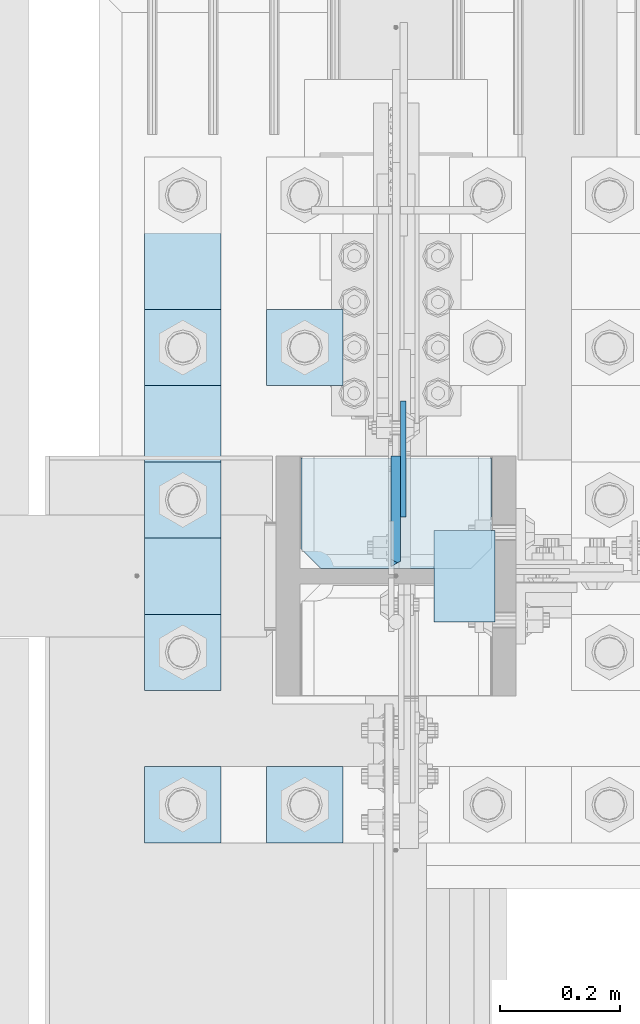
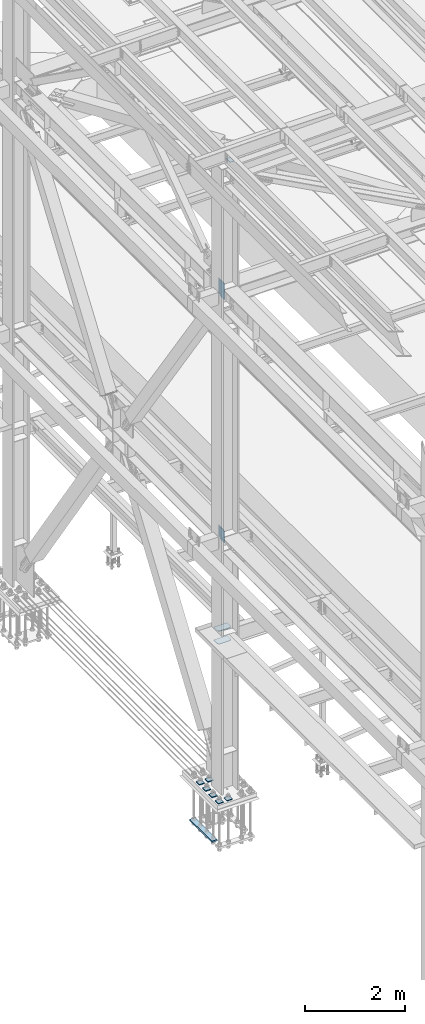
# One storey, part 3339 of 3843: 14 plates, 2 elements without a shape of their own.
"""IFC2X3 building model written with IfcOpenShell, lengths in millimetres."""

from ifc_helpers import new_model, si_unit, frame, origin_with_axes, place, context, subcontext, project, spatial, faceted_brep, material, type_object, element, aggregate, save


model = new_model("IFC2X3")

# Units and contexts
model_context = context("Model", 3, precision=1e-05, world=origin_with_axes())
body_context = subcontext(model_context, "Body", "Model", "MODEL_VIEW")
ifc_project = project(units=[si_unit("LENGTHUNIT", "METRE", prefix="MILLI"), si_unit("AREAUNIT", "SQUARE_METRE"), si_unit("VOLUMEUNIT", "CUBIC_METRE"), si_unit("MASSUNIT", "GRAM", prefix="KILO"), si_unit("TIMEUNIT", "SECOND"), si_unit("PLANEANGLEUNIT", "RADIAN"), si_unit("SOLIDANGLEUNIT", "STERADIAN"), si_unit("THERMODYNAMICTEMPERATUREUNIT", "DEGREE_CELSIUS"), si_unit("LUMINOUSINTENSITYUNIT", "LUMEN")], contexts=[model_context])

# Site, building, storey
site_placement = place(None, origin_with_axes())
site = spatial("IfcSite", under=ifc_project, at=site_placement, CompositionType="ELEMENT")
building_placement = place(site_placement, origin_with_axes())
building = spatial("IfcBuilding", under=site, at=building_placement, Name="Undefined", CompositionType="ELEMENT")
storey_placement = place(building_placement, origin_with_axes())
storey = spatial("IfcBuildingStorey", under=building, at=storey_placement, Name="Undefined", CompositionType="ELEMENT", Elevation=0.0)

# Assembly, plates
assembly_1_placement = place(storey_placement, origin_with_axes())
assembly_1 = element("IfcElementAssembly", 1, at=assembly_1_placement, inside=storey, Name="COLUMN", AssemblyPlace="NOTDEFINED", PredefinedType="RIGID_FRAME")
ifc_material = material(Name="STEEL/A572-50")
plate_type_1 = type_object("IfcPlateType", PredefinedType="NOTDEFINED")
plate_1_placement = place(assembly_1_placement, frame((36639.5, 67348.1000000002, 45422.542188), z_axis=(1.0, 0.0, 0.0), x_axis=(0.0, -1.0, 0.0)))
plate_1 = element("IfcPlate", 2, at=plate_1_placement, type_object=plate_type_1, material=ifc_material, Name="PLATE", context=body_context, shape_type="Brep", body=[
    faceted_brep([(0.0, -3.17499999999927, 0.0), (0.0, -3.17499999999927, 101.600000000006), (0.0, 3.17499999999927, 101.600000000006), (0.0, 3.17499999999927, 0.0), (152.399998474109, -3.17500000000291, 101.599998474121), (152.399998474109, 3.17500000000291, 101.599998474121), (152.399998474109, -3.17500000000291, 0.0), (152.399998474109, 3.17500000000291, 0.0)], [[[0, 1, 2, 3]], [[1, 4, 5, 2]], [[4, 6, 7, 5]], [[6, 0, 3, 7]], [[5, 7, 3, 2]], [[6, 4, 1, 0]]]),
])
plate_type_2 = type_object("IfcPlateType", PredefinedType="NOTDEFINED")
plate_2_placement = place(assembly_1_placement, frame((36587.90625, 67563.999998474, 42411.65), z_axis=(0.0, 0.0, -1.0), x_axis=(0.0, -1.0, 0.0)))
plate_2 = element("IfcPlate", 3, at=plate_2_placement, type_object=plate_type_2, material=ifc_material, Name="PLATE", context=body_context, shape_type="Brep", body=[
    faceted_brep([(0.0, -4.76249999999709, 0.0), (0.0, -4.76249999999709, 358.774999999994), (0.0, 4.76249999999709, 358.774999999994), (0.0, 4.76249999999709, 0.0), (193.674999999996, -4.76249999999709, 358.774999999994), (193.674999999996, 4.76249999999709, 358.774999999994), (193.674999999996, -4.76249999999709, 0.0), (193.674999999996, 4.76249999999709, 0.0)], [[[0, 1, 2, 3]], [[1, 4, 5, 2]], [[4, 6, 7, 5]], [[6, 0, 3, 7]], [[5, 7, 3, 2]], [[6, 4, 1, 0]]]),
])
plate_3_placement = place(assembly_1_placement, frame((36587.90625, 67563.999998474, 36387.0875), z_axis=(0.0, 0.0, -1.0), x_axis=(0.0, -1.0, 0.0)))
plate_3 = element("IfcPlate", 4, at=plate_3_placement, type_object=plate_type_2, material=ifc_material, Name="PLATE", context=body_context, shape_type="Brep", body=[
    faceted_brep([(0.0, -4.76249999999709, 0.0), (1.45519152283669e-11, -4.76249999999709, 269.874990844721), (1.45519152283669e-11, 4.76249999999709, 269.874990844721), (0.0, 4.76249999999709, 0.0), (193.675000000003, -4.76249999999709, 269.874990844721), (193.675000000003, 4.76249999999709, 269.874990844721), (193.674999999996, -4.76249999999709, 0.0), (193.674999999996, 4.76249999999709, 0.0)], [[[0, 1, 2, 3]], [[1, 4, 5, 2]], [[4, 6, 7, 5]], [[6, 0, 3, 7]], [[5, 7, 3, 2]], [[6, 4, 1, 0]]]),
])
plate_type_3 = type_object("IfcPlateType", PredefinedType="NOTDEFINED")
plate_4_placement = place(assembly_1_placement, frame((36575.20625, 67284.6000000004, 42049.7000027761), z_axis=(0.0, 0.707106781186548, 0.707106781186548), x_axis=(5.70000238222118e-08, 0.707106781186546, -0.707106781186546)))
plate_4 = element("IfcPlate", 5, at=plate_4_placement, type_object=plate_type_3, material=ifc_material, Name="PLATE", context=body_context, shape_type="Brep", body=[
    faceted_brep([(13.4703841830633, -7.9375, 3.98162703275011), (-254.200736442363, -7.93750000146974, 271.652747659384), (-258.182363479675, -3.06102270678093, 271.652747658118), (-258.182363479675, 7.9375, 262.672491473404), (4.49012799373304, 7.9375, 0.0), (13.4703841824085, -3.06102271161217, -3.63797880709171e-12), (-130.467612416627, -7.93750000095315, 395.3858675265), (-136.948905814113, 7.9375, 401.866457348944), (-258.18236347966, 7.9375, 280.633003841573), (22.4506403697887, 7.9375, -1.81898940354586e-11), (143.684450000996, 7.93749999987631, 121.233809668753), (137.203156365149, -7.9375, 127.714399252793), (124.601054452933, 7.9375, 140.3165009773), (124.601054452933, -7.9375, 140.3165009773), (-117.86586234005, 7.9375, 382.783414159065), (-117.86586234005, -7.9375, 382.783414159065)], [[[0, 1, 2, 3, 4, 5]], [[6, 7, 8, 2, 1]], [[9, 5, 4]], [[9, 10, 11, 0, 5]], [[12, 13, 11, 10]], [[14, 15, 13, 12]], [[11, 13, 15, 6, 1, 0]], [[8, 3, 2]], [[14, 12, 10, 9, 4, 3, 8, 7]], [[15, 14, 7, 6]]]),
])
plate_5_placement = place(assembly_1_placement, frame((36575.20625, 67284.6, 36121.975), z_axis=(0.0, 0.707106781186548, 0.707106781186548), x_axis=(5.70000238222118e-08, 0.707106781186546, -0.707106781186546)))
plate_5 = element("IfcPlate", 6, at=plate_5_placement, type_object=plate_type_3, material=ifc_material, Name="PLATE", context=body_context, shape_type="Brep", body=[
    faceted_brep([(-184.095250465922, 7.9375, 188.585378458942), (4.49012799373304, 7.9375, 0.0), (13.4703841824085, -3.06102271161217, -3.63797880709171e-12), (13.4703841830633, -7.9375, 3.98162703275011), (-180.113623446356, -7.9375, 197.565634661863), (-184.095250465834, -3.06102272757562, 197.565634661427), (-56.3805024272406, -7.93749995733378, 321.29875755457), (-62.861793789496, 7.9375, 327.779349412245), (-184.095250465754, 7.9375, 206.545890861948), (22.4506403697887, 7.9375, -1.81898940354586e-11), (143.684450000996, 7.93749999987631, 121.233809668753), (137.203156365149, -7.9375, 127.714399252793), (134.703841697788, 7.9375, 130.21371389494), (134.703841697788, -7.9375, 130.21371389494), (-53.8815365549381, 7.9375, 318.799092176701), (-53.8815365549381, -7.9375, 318.799092176701)], [[[0, 1, 2, 3, 4, 5]], [[6, 7, 8, 5, 4]], [[9, 2, 1]], [[9, 10, 11, 3, 2]], [[12, 13, 11, 10]], [[14, 15, 13, 12]], [[11, 13, 15, 6, 4, 3]], [[8, 0, 5]], [[14, 12, 10, 9, 1, 0, 8, 7]], [[15, 14, 7, 6]]]),
])
plate_type_4 = type_object("IfcPlateType", PredefinedType="NOTDEFINED")
plate_6_placement = place(assembly_1_placement, frame((36417.25, 67284.6, 33688.3375), z_axis=(1.0, 0.0, 0.0), x_axis=(0.0, 1.0, 0.0)))
plate_6 = element("IfcPlate", 7, at=plate_6_placement, type_object=plate_type_4, material=ifc_material, Name="PLATE", context=body_context, shape_type="Brep", body=[
    faceted_brep([(0.0, -4.76249999999709, 33.3375015258789), (0.0, -4.76249999999709, 284.162498474121), (0.0, 4.76249999999709, 284.162498474121), (0.0, 4.76249999999709, 33.3375015258789), (33.3375015258789, -4.76249999999709, 317.5), (33.3375015258789, 4.76249999999709, 317.5), (184.150000000009, -4.76249999999709, 317.5), (184.150000000009, 4.76249999999709, 317.5), (184.150000000009, -4.76249999999709, 0.0), (184.150000000009, 4.76249999999709, 0.0), (33.3375015258789, -4.76249999999709, 0.0), (33.3375015258789, 4.76249999999709, 0.0)], [[[0, 1, 2, 3]], [[1, 4, 5, 2]], [[4, 6, 7, 5]], [[6, 8, 9, 7]], [[8, 10, 11, 9]], [[10, 0, 3, 11]], [[5, 7, 9, 11, 3, 2]], [[10, 8, 6, 4, 1, 0]]]),
])
plate_7_placement = place(assembly_1_placement, frame((36417.25, 67284.6, 34002.6625), z_axis=(1.0, 0.0, 0.0), x_axis=(0.0, 1.0, 0.0)))
plate_7 = element("IfcPlate", 8, at=plate_7_placement, type_object=plate_type_4, material=ifc_material, Name="PLATE", context=body_context, shape_type="Brep", body=[
    faceted_brep([(0.0, -4.76249999999709, 33.3375015258789), (0.0, -4.76249999999709, 284.162498474121), (0.0, 4.76249999999709, 284.162498474121), (0.0, 4.76249999999709, 33.3375015258789), (33.3375015258789, -4.76249999999709, 317.5), (33.3375015258789, 4.76249999999709, 317.5), (184.150000000009, -4.76249999999709, 317.5), (184.150000000009, 4.76249999999709, 317.5), (184.150000000009, -4.76249999999709, 0.0), (184.150000000009, 4.76249999999709, 0.0), (33.3375015258789, -4.76249999999709, 0.0), (33.3375015258789, 4.76249999999709, 0.0)], [[[0, 1, 2, 3]], [[1, 4, 5, 2]], [[4, 6, 7, 5]], [[6, 8, 9, 7]], [[8, 10, 11, 9]], [[10, 0, 3, 11]], [[5, 7, 9, 11, 3, 2]], [[10, 8, 6, 4, 1, 0]]]),
])
aggregate(assembly_1, [plate_1, plate_2, plate_4, plate_3, plate_5, plate_6, plate_7])

assembly_2_placement = place(storey_placement, origin_with_axes())
assembly_2 = element("IfcElementAssembly", 9, at=assembly_2_placement, inside=storey, Name="TEMPLATE", AssemblyPlace="NOTDEFINED", PredefinedType="RIGID_FRAME")
plate_type_5 = type_object("IfcPlateType", PredefinedType="NOTDEFINED")
plate_8_placement = place(assembly_2_placement, frame((36360.1, 66954.4, 30172.025), z_axis=(0.0, -1.0, 0.0), x_axis=(1.0, 0.0, 0.0)))
plate_8 = element("IfcPlate", 10, at=plate_8_placement, type_object=plate_type_5, material=ifc_material, Name="Washer Plate", context=body_context, shape_type="Brep", body=[
    faceted_brep([(0.0, -9.52500000000146, 0.0), (0.0, -9.52499999999418, 127.0), (0.0, 9.52499999999418, 127.0), (0.0, 9.52500000000146, 0.0), (127.0, -9.52500000000146, 127.0), (127.0, 9.52500000000146, 127.0), (127.0, -9.52500000000146, 0.0), (127.0, 9.52500000000146, 0.0)], [[[0, 1, 2, 3]], [[1, 4, 5, 2]], [[4, 6, 7, 5]], [[6, 0, 3, 7]], [[5, 7, 3, 2]], [[6, 4, 1, 0]]]),
])
plate_9_placement = place(assembly_2_placement, frame((36360.1, 67716.4, 30172.025), z_axis=(0.0, -1.0, 0.0), x_axis=(1.0, 0.0, 0.0)))
plate_9 = element("IfcPlate", 11, at=plate_9_placement, type_object=plate_type_5, material=ifc_material, Name="Washer Plate", context=body_context, shape_type="Brep", body=[
    faceted_brep([(0.0, -9.52500000000146, 0.0), (0.0, -9.52499999999418, 127.0), (0.0, 9.52499999999418, 127.0), (0.0, 9.52500000000146, 0.0), (127.0, -9.52500000000146, 127.0), (127.0, 9.52500000000146, 127.0), (127.0, -9.52500000000146, 0.0), (127.0, 9.52500000000146, 0.0)], [[[0, 1, 2, 3]], [[1, 4, 5, 2]], [[4, 6, 7, 5]], [[6, 0, 3, 7]], [[5, 7, 3, 2]], [[6, 4, 1, 0]]]),
])
plate_10_placement = place(assembly_2_placement, frame((36156.9, 66954.4, 30172.025), z_axis=(0.0, -1.0, 0.0), x_axis=(1.0, 0.0, 0.0)))
plate_10 = element("IfcPlate", 12, at=plate_10_placement, type_object=plate_type_5, material=ifc_material, Name="Washer Plate", context=body_context, shape_type="Brep", body=[
    faceted_brep([(0.0, -9.52500000000146, 0.0), (0.0, -9.52499999999418, 127.0), (0.0, 9.52499999999418, 127.0), (0.0, 9.52500000000146, 0.0), (127.0, -9.52500000000146, 127.0), (127.0, 9.52500000000146, 127.0), (127.0, -9.52500000000146, 0.0), (127.0, 9.52500000000146, 0.0)], [[[0, 1, 2, 3]], [[1, 4, 5, 2]], [[4, 6, 7, 5]], [[6, 0, 3, 7]], [[5, 7, 3, 2]], [[6, 4, 1, 0]]]),
])
plate_11_placement = place(assembly_2_placement, frame((36156.9, 67208.4, 30172.025), z_axis=(0.0, -1.0, 0.0), x_axis=(1.0, 0.0, 0.0)))
plate_11 = element("IfcPlate", 13, at=plate_11_placement, type_object=plate_type_5, material=ifc_material, Name="Washer Plate", context=body_context, shape_type="Brep", body=[
    faceted_brep([(0.0, -9.52500000000146, 0.0), (0.0, -9.52499999999418, 127.0), (0.0, 9.52499999999418, 127.0), (0.0, 9.52500000000146, 0.0), (127.0, -9.52500000000146, 127.0), (127.0, 9.52500000000146, 127.0), (127.0, -9.52500000000146, 0.0), (127.0, 9.52500000000146, 0.0)], [[[0, 1, 2, 3]], [[1, 4, 5, 2]], [[4, 6, 7, 5]], [[6, 0, 3, 7]], [[5, 7, 3, 2]], [[6, 4, 1, 0]]]),
])
plate_12_placement = place(assembly_2_placement, frame((36156.9, 67462.4, 30172.025), z_axis=(0.0, -1.0, 0.0), x_axis=(1.0, 0.0, 0.0)))
plate_12 = element("IfcPlate", 14, at=plate_12_placement, type_object=plate_type_5, material=ifc_material, Name="Washer Plate", context=body_context, shape_type="Brep", body=[
    faceted_brep([(0.0, -9.52500000000146, 0.0), (0.0, -9.52499999999418, 127.0), (0.0, 9.52499999999418, 127.0), (0.0, 9.52500000000146, 0.0), (127.0, -9.52500000000146, 127.0), (127.0, 9.52500000000146, 127.0), (127.0, -9.52500000000146, 0.0), (127.0, 9.52500000000146, 0.0)], [[[0, 1, 2, 3]], [[1, 4, 5, 2]], [[4, 6, 7, 5]], [[6, 0, 3, 7]], [[5, 7, 3, 2]], [[6, 4, 1, 0]]]),
])
plate_13_placement = place(assembly_2_placement, frame((36156.9, 67716.4, 30172.025), z_axis=(0.0, -1.0, 0.0), x_axis=(1.0, 0.0, 0.0)))
plate_13 = element("IfcPlate", 15, at=plate_13_placement, type_object=plate_type_5, material=ifc_material, Name="Washer Plate", context=body_context, shape_type="Brep", body=[
    faceted_brep([(0.0, -9.52500000000146, 0.0), (0.0, -9.52499999999418, 127.0), (0.0, 9.52499999999418, 127.0), (0.0, 9.52500000000146, 0.0), (127.0, -9.52500000000146, 127.0), (127.0, 9.52500000000146, 127.0), (127.0, -9.52500000000146, 0.0), (127.0, 9.52500000000146, 0.0)], [[[0, 1, 2, 3]], [[1, 4, 5, 2]], [[4, 6, 7, 5]], [[6, 0, 3, 7]], [[5, 7, 3, 2]], [[6, 4, 1, 0]]]),
])
plate_type_6 = type_object("IfcPlateType", PredefinedType="NOTDEFINED")
plate_14_placement = place(assembly_2_placement, frame((36156.9, 67081.4, 29089.35), z_axis=(0.0, 1.0, 0.0), x_axis=(1.0, 0.0, 0.0)))
plate_14 = element("IfcPlate", 16, at=plate_14_placement, type_object=plate_type_6, material=ifc_material, Name="PLATE", context=body_context, shape_type="Brep", body=[
    faceted_brep([(0.0, -19.0500000000029, 0.0), (-7.27595761418343e-12, -19.0499999999993, 889.0), (-7.27595761418343e-12, 19.0499999999993, 889.0), (0.0, 19.0500000000029, 0.0), (127.0, -19.0499999999993, 889.0), (127.0, 19.0499999999993, 889.0), (127.0, -19.0499999999993, 0.0), (127.0, 19.0499999999993, 0.0)], [[[0, 1, 2, 3]], [[1, 4, 5, 2]], [[4, 6, 7, 5]], [[6, 0, 3, 7]], [[5, 7, 3, 2]], [[6, 4, 1, 0]]]),
])
aggregate(assembly_2, [plate_8, plate_9, plate_10, plate_11, plate_12, plate_13, plate_14])

save(model, "model.ifc")
